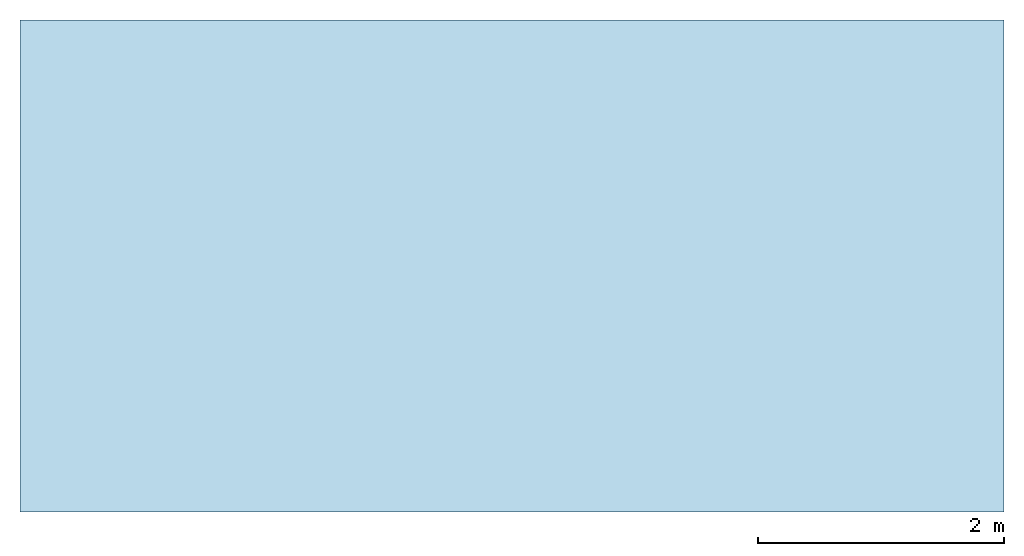
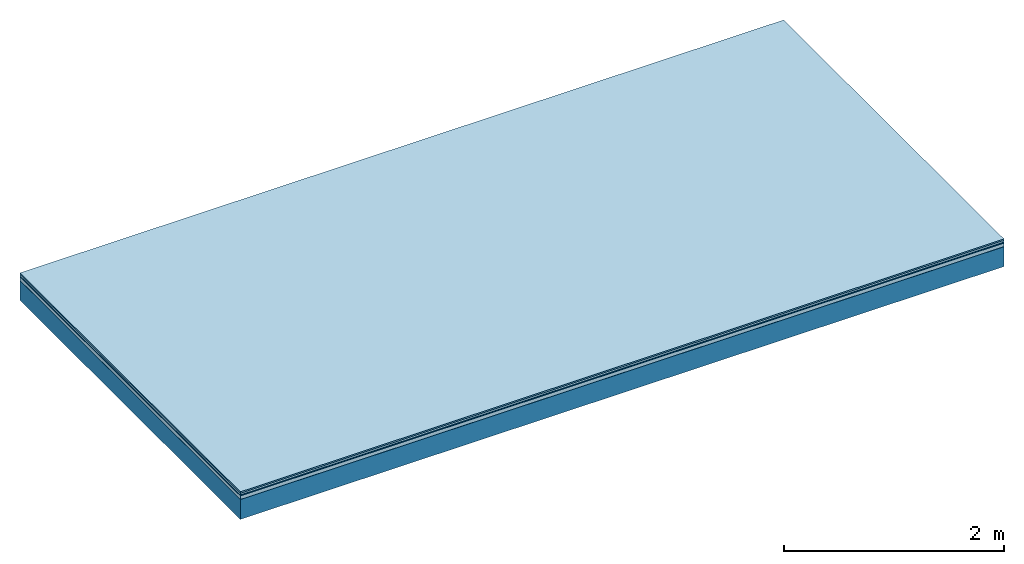
# One storey: 5 plates, 1 member, 1 element without a shape of its own.
"""IFC4 building model written with IfcOpenShell, lengths in metres."""

from ifc_helpers import new_model, si_unit, derived_unit, direction, frame, frame_2d, origin, origin_with_axes, place, context, project, spatial, rectangle, extrude, material, layer, layer_set, type_object, element, aggregate, save


model = new_model("IFC4")

# Units and contexts
plan_context = context("Plan", 3, precision=1e-05, world=origin(), true_north=direction((0.0, 1.0)))
model_context = context("Model", 3, precision=1e-05, world=origin(), true_north=direction((0.0, 1.0)))
ifc_project = project(units=[si_unit("LENGTHUNIT", "METRE"), derived_unit("SOUNDPRESSUREUNIT", [(si_unit("PRESSUREUNIT", "PASCAL", prefix="MICRO"), 0)]), si_unit("ENERGYUNIT", "JOULE", prefix="MEGA"), si_unit("MASSUNIT", "GRAM", prefix="KILO"), derived_unit("THERMALTRANSMITTANCEUNIT", [(si_unit("POWERUNIT", "WATT"), 1), (si_unit("AREAUNIT", "SQUARE_METRE"), -1), (si_unit("THERMODYNAMICTEMPERATUREUNIT", "KELVIN"), -1)]), derived_unit("AREADENSITYUNIT", [(si_unit("MASSUNIT", "GRAM", prefix="KILO"), 1), (si_unit("AREAUNIT", "SQUARE_METRE"), -1)]), derived_unit("USERDEFINED", [(si_unit("ENERGYUNIT", "JOULE", prefix="MEGA"), 1), (si_unit("AREAUNIT", "SQUARE_METRE"), -1)])], contexts=[plan_context, model_context])

# Site, building, storey
site = spatial("IfcSite", under=ifc_project)
building_placement = place(None, origin())
building = spatial("IfcBuilding", under=site, at=building_placement)
storey_placement = place(building_placement, origin())
storey = spatial("IfcBuildingStorey", under=building, at=storey_placement)

# Slab, member, plates
ifc_material_1 = material(Category="11.013")
ifc_layer_1 = layer(ifc_material_1, 0.015, Name="Flooring")
ifc_material_2 = material(Category="03.007")
ifc_layer_2 = layer(ifc_material_2, 0.02, Name="On-material")
ifc_material_3 = material(Name="Wood fiber generic product", Category="10.009")
ifc_layer_3 = layer(ifc_material_3, 0.01, Name="Impact sound insulation")
ifc_material_4 = material(Name="Cement panels, glued on sub-floor", Category="02.007")
ifc_layer_4 = layer(ifc_material_4, 0.04, Name="on Supporting structure")
ifc_material_5 = material(Name="protection", Category="09.007")
ifc_layer_5 = layer(ifc_material_5, 0.0005, Name="Sub-floor")
ifc_material_6 = material(Name="no composite action")
ifc_layer_6 = layer(ifc_material_6, 0.0, Name="Bond")
ifc_layer_7 = layer(None, 0.22, Name="Supporting structure")
ifc_layer_set = layer_set([ifc_layer_1, ifc_layer_2, ifc_layer_3, ifc_layer_4, ifc_layer_5, ifc_layer_6, ifc_layer_7])
slab_type = type_object("IfcSlabType", Name="A2065", PredefinedType="NOTDEFINED", material=ifc_layer_set)
slab_placement = place(None, frame((0.0, 0.0, 0.0), z_axis=(0.0, 0.0, -1.0), x_axis=(1.0, 0.0, 0.0)))
slab = element("IfcSlab", 1, at=slab_placement, inside=storey, type_object=slab_type, material=ifc_layer_set, Name="Slab #1")
ifc_material_7 = material(Name="Solid timber panel")
member_placement = place(slab_placement, origin())
member = element("IfcMember", 2, at=member_placement, material=ifc_material_7, Name="Supporting structure", context=plan_context, shape_type="SweptSolid", body=[
    extrude(rectangle(XDim=1.0, YDim=0.22, at=frame_2d((0.5, 0.11), x_axis=(1.0, 0.0))), frame((0.0, 4.0, 0.0855), z_axis=(0.0, -1.0, 0.0), x_axis=(1.0, 0.0, 0.0)), (0.0, 0.0, 1.0), 4.0),
    extrude(rectangle(XDim=1.0, YDim=0.22, at=frame_2d((0.5, 0.11), x_axis=(1.0, 0.0))), frame((1.0, 4.0, 0.0855), z_axis=(0.0, -1.0, 0.0), x_axis=(1.0, 0.0, 0.0)), (0.0, 0.0, 1.0), 4.0),
    extrude(rectangle(XDim=1.0, YDim=0.22, at=frame_2d((0.5, 0.11), x_axis=(1.0, 0.0))), frame((2.0, 4.0, 0.0855), z_axis=(0.0, -1.0, 0.0), x_axis=(1.0, 0.0, 0.0)), (0.0, 0.0, 1.0), 4.0),
    extrude(rectangle(XDim=1.0, YDim=0.22, at=frame_2d((0.5, 0.11), x_axis=(1.0, 0.0))), frame((3.0, 4.0, 0.0855), z_axis=(0.0, -1.0, 0.0), x_axis=(1.0, 0.0, 0.0)), (0.0, 0.0, 1.0), 4.0),
    extrude(rectangle(XDim=1.0, YDim=0.22, at=frame_2d((0.5, 0.11), x_axis=(1.0, 0.0))), frame((4.0, 4.0, 0.0855), z_axis=(0.0, -1.0, 0.0), x_axis=(1.0, 0.0, 0.0)), (0.0, 0.0, 1.0), 4.0),
    extrude(rectangle(XDim=1.0, YDim=0.22, at=frame_2d((0.5, 0.11), x_axis=(1.0, 0.0))), frame((5.0, 4.0, 0.0855), z_axis=(0.0, -1.0, 0.0), x_axis=(1.0, 0.0, 0.0)), (0.0, 0.0, 1.0), 4.0),
    extrude(rectangle(XDim=1.0, YDim=0.22, at=frame_2d((0.5, 0.11), x_axis=(1.0, 0.0))), frame((6.0, 4.0, 0.0855), z_axis=(0.0, -1.0, 0.0), x_axis=(1.0, 0.0, 0.0)), (0.0, 0.0, 1.0), 4.0),
    extrude(rectangle(XDim=1.0, YDim=0.22, at=frame_2d((0.5, 0.11), x_axis=(1.0, 0.0))), frame((7.0, 4.0, 0.0855), z_axis=(0.0, -1.0, 0.0), x_axis=(1.0, 0.0, 0.0)), (0.0, 0.0, 1.0), 4.0),
])
plate_1_placement = place(slab_placement, origin())
plate_1 = element("IfcPlate", 3, at=plate_1_placement, material=ifc_material_1, Name="Flooring", context=plan_context, shape_type="SweptSolid", body=[
    extrude(rectangle(XDim=8.0, YDim=4.0, at=frame_2d((4.0, 2.0), x_axis=(1.0, 0.0))), origin_with_axes(), (0.0, 0.0, 1.0), 0.015),
])
plate_2_placement = place(slab_placement, origin())
plate_2 = element("IfcPlate", 4, at=plate_2_placement, material=ifc_material_2, Name="On-material", context=plan_context, shape_type="SweptSolid", body=[
    extrude(rectangle(XDim=8.0, YDim=4.0, at=frame_2d((4.0, 2.0), x_axis=(1.0, 0.0))), frame((0.0, 0.0, 0.015), z_axis=(0.0, 0.0, 1.0), x_axis=(1.0, 0.0, 0.0)), (0.0, 0.0, 1.0), 0.02),
])
plate_3_placement = place(slab_placement, origin())
plate_3 = element("IfcPlate", 5, at=plate_3_placement, material=ifc_material_3, Name="Impact sound insulation", context=plan_context, shape_type="SweptSolid", body=[
    extrude(rectangle(XDim=8.0, YDim=4.0, at=frame_2d((4.0, 2.0), x_axis=(1.0, 0.0))), frame((0.0, 0.0, 0.035), z_axis=(0.0, 0.0, 1.0), x_axis=(1.0, 0.0, 0.0)), (0.0, 0.0, 1.0), 0.01),
])
plate_4_placement = place(slab_placement, origin())
plate_4 = element("IfcPlate", 6, at=plate_4_placement, material=ifc_material_4, Name="on Supporting structure", context=plan_context, shape_type="SweptSolid", body=[
    extrude(rectangle(XDim=8.0, YDim=4.0, at=frame_2d((4.0, 2.0), x_axis=(1.0, 0.0))), frame((0.0, 0.0, 0.045), z_axis=(0.0, 0.0, 1.0), x_axis=(1.0, 0.0, 0.0)), (0.0, 0.0, 1.0), 0.04),
])
plate_5_placement = place(slab_placement, origin())
plate_5 = element("IfcPlate", 7, at=plate_5_placement, material=ifc_material_5, Name="Sub-floor", context=plan_context, shape_type="SweptSolid", body=[
    extrude(rectangle(XDim=8.0, YDim=4.0, at=frame_2d((4.0, 2.0), x_axis=(1.0, 0.0))), frame((0.0, 0.0, 0.085), z_axis=(0.0, 0.0, 1.0), x_axis=(1.0, 0.0, 0.0)), (0.0, 0.0, 1.0), 0.0005),
])
aggregate(slab, [plate_1, plate_2, plate_3, plate_4, plate_5, member])

save(model, "model.ifc")
